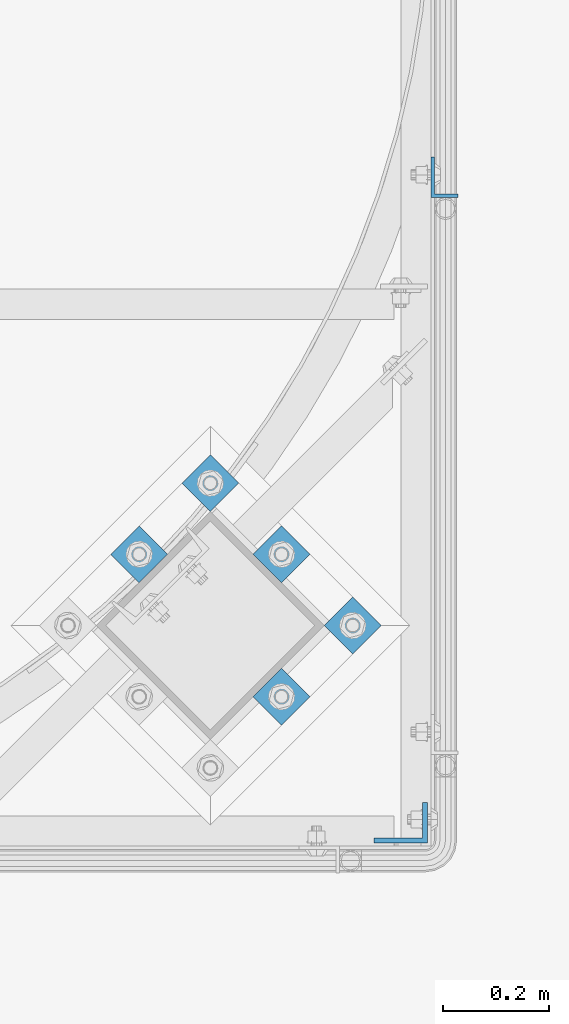
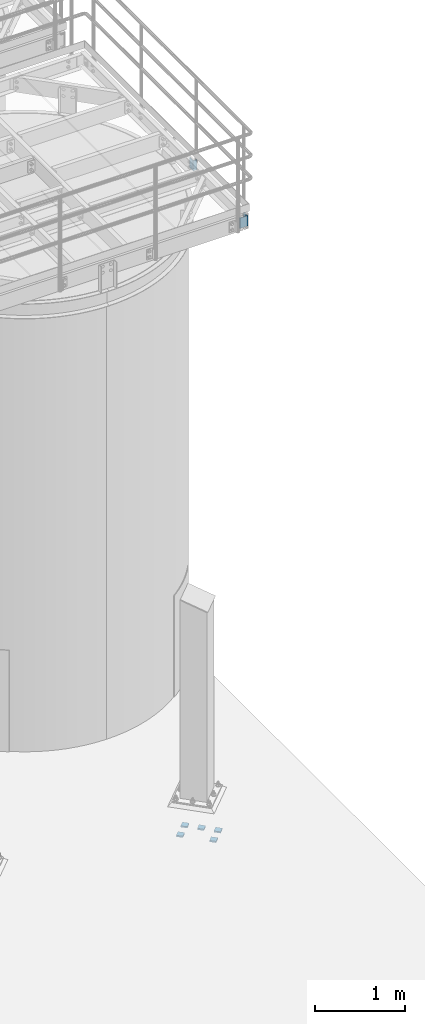
# One storey, part 1103 of 1876: 7 beams, 3 elements without a shape of their own.
"""IFC2X3 building model written with IfcOpenShell, lengths in millimetres."""

from ifc_helpers import new_model, si_unit, frame, origin_with_axes, place, context, subcontext, project, spatial, faceted_brep, material, type_object, element, aggregate, save


model = new_model("IFC2X3")

# Units and contexts
model_context = context("Model", 3, precision=1e-05, world=origin_with_axes())
body_context = subcontext(model_context, "Body", "Model", "MODEL_VIEW")
ifc_project = project(units=[si_unit("LENGTHUNIT", "METRE", prefix="MILLI"), si_unit("AREAUNIT", "SQUARE_METRE"), si_unit("VOLUMEUNIT", "CUBIC_METRE"), si_unit("MASSUNIT", "GRAM", prefix="KILO"), si_unit("TIMEUNIT", "SECOND"), si_unit("PLANEANGLEUNIT", "RADIAN"), si_unit("SOLIDANGLEUNIT", "STERADIAN"), si_unit("THERMODYNAMICTEMPERATUREUNIT", "DEGREE_CELSIUS"), si_unit("LUMINOUSINTENSITYUNIT", "LUMEN")], contexts=[model_context])

# Site, building, storey
site_placement = place(None, origin_with_axes())
site = spatial("IfcSite", under=ifc_project, at=site_placement, CompositionType="ELEMENT")
building_placement = place(site_placement, origin_with_axes())
building = spatial("IfcBuilding", under=site, at=building_placement, Name="Undefined", CompositionType="ELEMENT")
storey_placement = place(building_placement, origin_with_axes())
storey = spatial("IfcBuildingStorey", under=building, at=storey_placement, Name="Undefined", CompositionType="ELEMENT", Elevation=0.0)

# Assembly, beam
assembly_1_placement = place(storey_placement, origin_with_axes())
assembly_1 = element("IfcElementAssembly", 1, at=assembly_1_placement, inside=storey, Name="HANDRAIL", AssemblyPlace="NOTDEFINED", PredefinedType="RIGID_FRAME")
ifc_material = material(Name="STEEL/A36")
beam_type_1 = type_object("IfcBeamType", Name="L3X2X1/4", PredefinedType="NOTDEFINED")
beam_1_placement = place(assembly_1_placement, frame((7023.09856849878, -14139.3824042969, 7966.075), z_axis=(0.0, 1.0, 0.0), x_axis=(0.0, 0.0, -1.0)))
beam_1 = element("IfcBeam", 2, at=beam_1_placement, type_object=beam_type_1, material=ifc_material, Name="ANGLE", ObjectType="L3X2X1/4", context=body_context, shape_type="Brep", body=[
    faceted_brep([(0.0, 25.3999999999996, -38.1000000000004), (0.0, 25.3999999999996, 38.1000000000004), (139.7, 25.3999999999996, 38.1000000000004), (139.7, 25.3999999999996, -38.1000000000004), (0.0, 19.0500000000002, 38.1000000000004), (139.7, 19.0500000000002, 38.1000000000004), (0.0, 19.0500000000002, -31.75), (139.7, 19.0500000000002, -31.75), (0.0, -25.3999999999996, -31.75), (139.7, -25.3999999999996, -31.75), (0.0, -25.3999999999996, -38.1000000000004), (139.7, -25.3999999999996, -38.1000000000004)], [[[0, 1, 2, 3]], [[1, 4, 5, 2]], [[4, 6, 7, 5]], [[6, 8, 9, 7]], [[8, 10, 11, 9]], [[10, 0, 3, 11]], [[5, 7, 9, 11, 3, 2]], [[10, 8, 6, 4, 1, 0]]]),
])
aggregate(assembly_1, [beam_1])

assembly_2_placement = place(storey_placement, origin_with_axes())
assembly_2 = element("IfcElementAssembly", 3, at=assembly_2_placement, inside=storey, Name="BEAM", AssemblyPlace="NOTDEFINED", PredefinedType="RIGID_FRAME")
beam_type_2 = type_object("IfcBeamType", Name="L4X3X3/8", PredefinedType="NOTDEFINED")
beam_2_placement = place(assembly_2_placement, frame((6940.54856849878, -15360.6144042969, 7966.075), z_axis=(-1.0, 0.0, 0.0), x_axis=(0.0, 0.0, -1.0)))
beam_2 = element("IfcBeam", 4, at=beam_2_placement, type_object=beam_type_2, material=ifc_material, Name="ANGLE", ObjectType="L4X3X3/8", context=body_context, shape_type="Brep", body=[
    faceted_brep([(0.0, 38.1000000000004, -50.8000000000002), (0.0, 38.1000000000004, 50.8000000000002), (139.7, 38.1000000000004, 50.8000000000002), (139.7, 38.1000000000004, -50.8000000000002), (0.0, 28.5749999999998, 50.8000000000002), (139.700000000001, 28.5749999999998, 50.8000000000002), (0.0, 28.5749999999998, -41.2749999999996), (139.700000000001, 28.5749999999998, -41.2749999999996), (0.0, -38.1000000000004, -41.2749999999996), (139.700000000001, -38.1000000000004, -41.2749999999996), (0.0, -38.1000000000004, -50.8000000000002), (139.7, -38.1000000000004, -50.8000000000002)], [[[0, 1, 2, 3]], [[1, 4, 5, 2]], [[4, 6, 7, 5]], [[6, 8, 9, 7]], [[8, 10, 11, 9]], [[10, 0, 3, 11]], [[5, 7, 9, 11, 3, 2]], [[10, 8, 6, 4, 1, 0]]]),
])
aggregate(assembly_2, [beam_2])

# Assembly, beams
assembly_3_placement = place(storey_placement, origin_with_axes())
assembly_3 = element("IfcElementAssembly", 5, at=assembly_3_placement, inside=storey, Name="TEMPLATE", AssemblyPlace="NOTDEFINED", PredefinedType="RIGID_FRAME")
beam_type_3 = type_object("IfcBeamType", PredefinedType="NOTDEFINED")
beam_3_placement = place(assembly_3_placement, frame((6876.62334285216, -14960.5916220471, -542.925), z_axis=(-0.707106781186548, 0.707106781186547, 0.0), x_axis=(-0.707106781186547, -0.707106781186548, 0.0)))
beam_3 = element("IfcBeam", 6, at=beam_3_placement, type_object=beam_type_3, material=ifc_material, Name="PLATE", context=body_context, shape_type="Brep", body=[
    faceted_brep([(0.0, 9.52499999999998, -38.1000000000058), (-9.09494701772928e-13, 9.52499999999998, 38.1000000000076), (76.2000000000762, 9.52499999999998, 38.1000000000058), (76.2000000000762, 9.52499999999998, -38.1000000000058), (-9.09494701772928e-13, -9.52499999999998, 38.1000000000076), (76.2000000000762, -9.52499999999998, 38.1000000000058), (0.0, -9.52499999999998, -38.1000000000058), (76.2000000000762, -9.52499999999998, -38.1000000000058)], [[[0, 1, 2, 3]], [[1, 4, 5, 2]], [[4, 6, 7, 5]], [[6, 0, 3, 7]], [[5, 7, 3, 2]], [[6, 4, 1, 0]]]),
])
beam_4_placement = place(assembly_3_placement, frame((6741.91950103601, -14825.887780231, -542.925), z_axis=(-0.707106781186548, 0.707106781186547, 0.0), x_axis=(-0.707106781186547, -0.707106781186548, 0.0)))
beam_4 = element("IfcBeam", 7, at=beam_4_placement, type_object=beam_type_3, material=ifc_material, Name="PLATE", context=body_context, shape_type="Brep", body=[
    faceted_brep([(0.0, 9.52499999999998, -38.1000000000058), (-9.09494701772928e-13, 9.52499999999998, 38.1000000000076), (76.2000000000762, 9.52499999999998, 38.1000000000058), (76.2000000000762, 9.52499999999998, -38.1000000000058), (-9.09494701772928e-13, -9.52499999999998, 38.1000000000076), (76.2000000000762, -9.52499999999998, 38.1000000000058), (0.0, -9.52499999999998, -38.1000000000058), (76.2000000000762, -9.52499999999998, -38.1000000000058)], [[[0, 1, 2, 3]], [[1, 4, 5, 2]], [[4, 6, 7, 5]], [[6, 0, 3, 7]], [[5, 7, 3, 2]], [[6, 4, 1, 0]]]),
])
beam_5_placement = place(assembly_3_placement, frame((6607.21565921986, -14691.1839384148, -542.925), z_axis=(-0.707106781186548, 0.707106781186547, 0.0), x_axis=(-0.707106781186547, -0.707106781186548, 0.0)))
beam_5 = element("IfcBeam", 8, at=beam_5_placement, type_object=beam_type_3, material=ifc_material, Name="PLATE", context=body_context, shape_type="Brep", body=[
    faceted_brep([(0.0, 9.52499999999998, -38.1000000000058), (-9.09494701772928e-13, 9.52499999999998, 38.1000000000076), (76.2000000000762, 9.52499999999998, 38.1000000000058), (76.2000000000762, 9.52499999999998, -38.1000000000058), (-9.09494701772928e-13, -9.52499999999998, 38.1000000000076), (76.2000000000762, -9.52499999999998, 38.1000000000058), (0.0, -9.52499999999998, -38.1000000000058), (76.2000000000762, -9.52499999999998, -38.1000000000058)], [[[0, 1, 2, 3]], [[1, 4, 5, 2]], [[4, 6, 7, 5]], [[6, 0, 3, 7]], [[5, 7, 3, 2]], [[6, 4, 1, 0]]]),
])
beam_6_placement = place(assembly_3_placement, frame((6741.91950103601, -15095.2954638633, -542.925), z_axis=(-0.707106781186548, 0.707106781186547, 0.0), x_axis=(-0.707106781186547, -0.707106781186548, 0.0)))
beam_6 = element("IfcBeam", 9, at=beam_6_placement, type_object=beam_type_3, material=ifc_material, Name="PLATE", context=body_context, shape_type="Brep", body=[
    faceted_brep([(0.0, 9.52499999999998, -38.1000000000058), (-9.09494701772928e-13, 9.52499999999998, 38.1000000000076), (76.2000000000762, 9.52499999999998, 38.1000000000058), (76.2000000000762, 9.52499999999998, -38.1000000000058), (-9.09494701772928e-13, -9.52499999999998, 38.1000000000076), (76.2000000000762, -9.52499999999998, 38.1000000000058), (0.0, -9.52499999999998, -38.1000000000058), (76.2000000000762, -9.52499999999998, -38.1000000000058)], [[[0, 1, 2, 3]], [[1, 4, 5, 2]], [[4, 6, 7, 5]], [[6, 0, 3, 7]], [[5, 7, 3, 2]], [[6, 4, 1, 0]]]),
])
beam_7_placement = place(assembly_3_placement, frame((6472.5118174037, -14825.887780231, -542.925), z_axis=(-0.707106781186548, 0.707106781186547, 0.0), x_axis=(-0.707106781186547, -0.707106781186548, 0.0)))
beam_7 = element("IfcBeam", 10, at=beam_7_placement, type_object=beam_type_3, material=ifc_material, Name="PLATE", context=body_context, shape_type="Brep", body=[
    faceted_brep([(0.0, 9.52499999999998, -38.1000000000058), (-9.09494701772928e-13, 9.52499999999998, 38.1000000000076), (76.2000000000762, 9.52499999999998, 38.1000000000058), (76.2000000000762, 9.52499999999998, -38.1000000000058), (-9.09494701772928e-13, -9.52499999999998, 38.1000000000076), (76.2000000000762, -9.52499999999998, 38.1000000000058), (0.0, -9.52499999999998, -38.1000000000058), (76.2000000000762, -9.52499999999998, -38.1000000000058)], [[[0, 1, 2, 3]], [[1, 4, 5, 2]], [[4, 6, 7, 5]], [[6, 0, 3, 7]], [[5, 7, 3, 2]], [[6, 4, 1, 0]]]),
])
aggregate(assembly_3, [beam_3, beam_4, beam_5, beam_6, beam_7])

save(model, "model.ifc")
